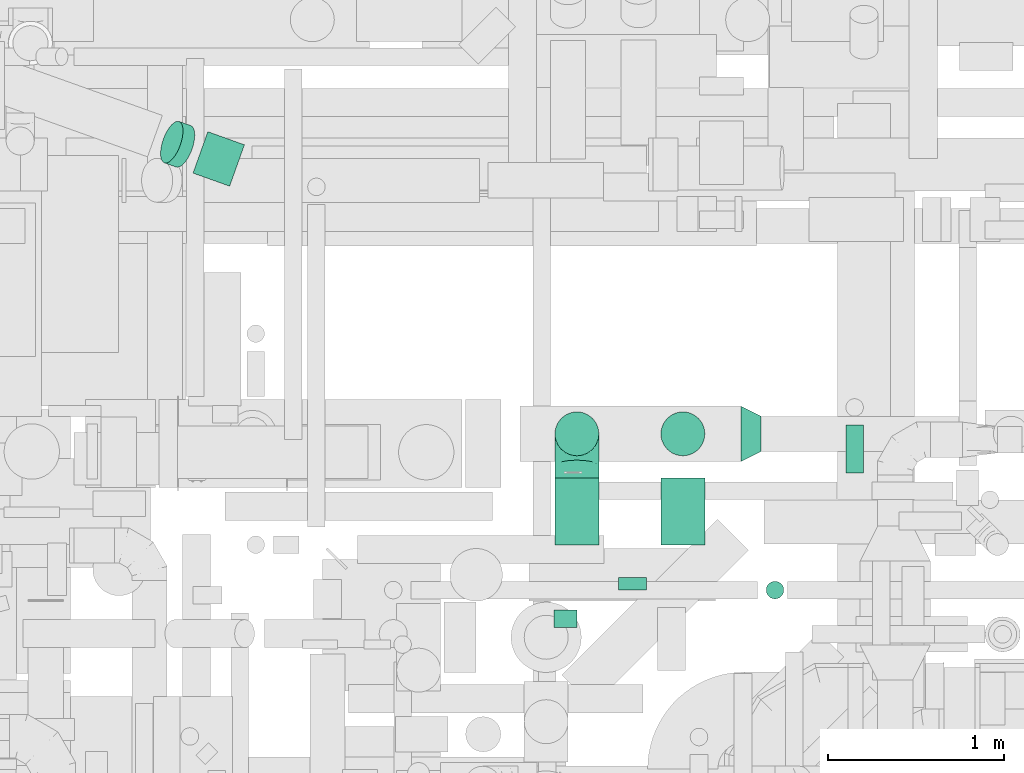
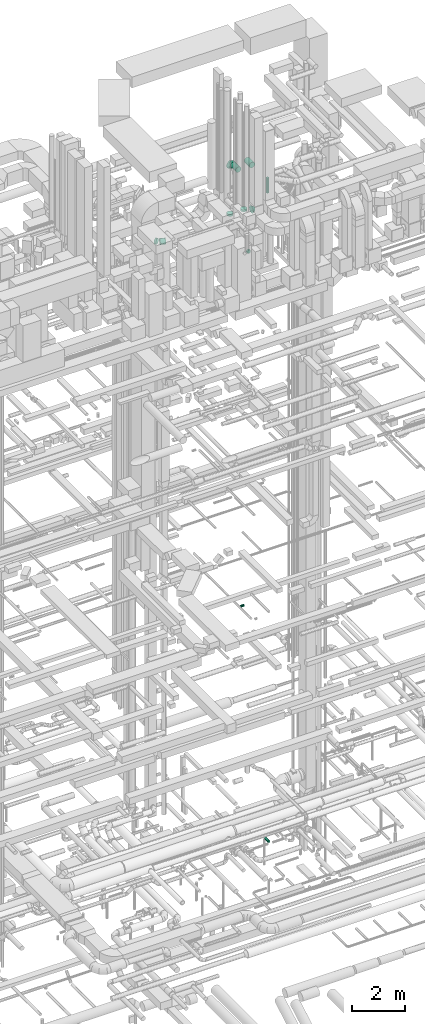
# One storey, part 247 of 337: 8 flow segments, 4 flow fittings.
"""IFC2X3 building model written with IfcOpenShell, lengths in millimetres."""

from ifc_helpers import new_model, entity, si_unit, converted_unit, derived_unit, direction, frame, origin, origin_2d_with_axis, place, context, subcontext, project, spatial, circle, extrude, faceted_brep, source, transform, mapped, material, type_object, type_shapes, element, save


model = new_model("IFC2X3")

# Units and contexts
model_context = context("Model", 3, precision=0.01, world=origin(), true_north=direction((6.12303176911189e-17, 1.0)))
body_context = subcontext(model_context, "Body", "Model", "MODEL_VIEW")
ifc_project = project(units=[si_unit("LENGTHUNIT", "METRE", prefix="MILLI"), si_unit("AREAUNIT", "SQUARE_METRE"), si_unit("VOLUMEUNIT", "CUBIC_METRE"), converted_unit("PLANEANGLEUNIT", "DEGREE", entity("IfcRatioMeasure", 0.0174532925199433), si_unit("PLANEANGLEUNIT", "RADIAN"), dimensions=[0, 0, 0, 0, 0, 0, 0]), si_unit("MASSUNIT", "GRAM", prefix="KILO"), derived_unit("MASSDENSITYUNIT", [(si_unit("MASSUNIT", "GRAM", prefix="KILO"), 1), (si_unit("LENGTHUNIT", "METRE"), -3)]), derived_unit("MOMENTOFINERTIAUNIT", [(si_unit("LENGTHUNIT", "METRE"), 4)]), si_unit("TIMEUNIT", "SECOND"), si_unit("FREQUENCYUNIT", "HERTZ"), si_unit("THERMODYNAMICTEMPERATUREUNIT", "DEGREE_CELSIUS"), derived_unit("THERMALTRANSMITTANCEUNIT", [(si_unit("MASSUNIT", "GRAM", prefix="KILO"), 1), (si_unit("THERMODYNAMICTEMPERATUREUNIT", "KELVIN"), -1), (si_unit("TIMEUNIT", "SECOND"), -3)]), derived_unit("VOLUMETRICFLOWRATEUNIT", [(si_unit("LENGTHUNIT", "METRE"), 3), (si_unit("TIMEUNIT", "SECOND"), -1)]), derived_unit("MASSFLOWRATEUNIT", [(si_unit("MASSUNIT", "GRAM", prefix="KILO"), 1), (si_unit("TIMEUNIT", "SECOND"), -1)]), derived_unit("ROTATIONALFREQUENCYUNIT", [(si_unit("TIMEUNIT", "SECOND"), -1)]), si_unit("ELECTRICCURRENTUNIT", "AMPERE"), si_unit("ELECTRICVOLTAGEUNIT", "VOLT"), si_unit("POWERUNIT", "WATT"), si_unit("FORCEUNIT", "NEWTON", prefix="KILO"), si_unit("ILLUMINANCEUNIT", "LUX"), si_unit("LUMINOUSFLUXUNIT", "LUMEN"), si_unit("LUMINOUSINTENSITYUNIT", "CANDELA"), derived_unit("USERDEFINED", [(si_unit("MASSUNIT", "GRAM", prefix="KILO"), -1), (si_unit("LENGTHUNIT", "METRE"), -2), (si_unit("TIMEUNIT", "SECOND"), 3), (si_unit("LUMINOUSFLUXUNIT", "LUMEN"), 1)]), derived_unit("LINEARVELOCITYUNIT", [(si_unit("LENGTHUNIT", "METRE"), 1), (si_unit("TIMEUNIT", "SECOND"), -1)]), si_unit("PRESSUREUNIT", "PASCAL"), derived_unit("USERDEFINED", [(si_unit("LENGTHUNIT", "METRE"), -2), (si_unit("MASSUNIT", "GRAM", prefix="KILO"), 1), (si_unit("TIMEUNIT", "SECOND"), -2)]), derived_unit("LINEARFORCEUNIT", [(si_unit("MASSUNIT", "GRAM", prefix="KILO"), 1), (si_unit("LENGTHUNIT", "METRE"), 1), (si_unit("TIMEUNIT", "SECOND"), -2), (si_unit("LENGTHUNIT", "METRE"), -1)]), derived_unit("PLANARFORCEUNIT", [(si_unit("MASSUNIT", "GRAM", prefix="KILO"), 1), (si_unit("LENGTHUNIT", "METRE"), 1), (si_unit("TIMEUNIT", "SECOND"), -2), (si_unit("LENGTHUNIT", "METRE"), -2)])], contexts=[model_context])

# Site, building, storey
site_placement = place(None, origin())
site = spatial("IfcSite", under=ifc_project, at=site_placement, CompositionType="ELEMENT")
building_placement = place(site_placement, origin())
building = spatial("IfcBuilding", under=site, at=building_placement, CompositionType="ELEMENT")
storey_placement = place(building_placement, origin())
storey = spatial("IfcBuildingStorey", under=building, at=storey_placement, CompositionType="ELEMENT", Elevation=0.0)

# Flow segments
duct_segment_type = type_object("IfcDuctSegmentType", PredefinedType="NOTDEFINED")
flow_segment_1_placement = place(storey_placement, frame((58022.61, 12771.08, -571.6)))
element("IfcFlowSegment", 1, at=flow_segment_1_placement, inside=storey, type_object=duct_segment_type, context=body_context, shape_type="SweptSolid", body=[
    extrude(circle(Radius=50.0, at=origin_2d_with_axis()), frame((51.6, 0.0, 51.6), z_axis=(0.0, 1.0, 0.0), x_axis=(1.0, 0.0, 0.0)), (0.0, 0.0, 1.0), 272.933650000004),
])
flow_segment_2_placement = place(storey_placement, frame((56365.61, 11891.09, 11398.4)))
element("IfcFlowSegment", 2, at=flow_segment_2_placement, inside=storey, type_object=duct_segment_type, context=body_context, shape_type="SweptSolid", body=[
    extrude(circle(Radius=50.0, at=origin_2d_with_axis()), frame((0.0, 51.6, 51.6), z_axis=(1.0, 0.0, 0.0), x_axis=(0.0, -1.0, 0.0)), (0.0, 0.0, 1.0), 129.999999999996),
])
flow_segment_3_placement = place(storey_placement, frame((54310.89, 14400.57, 27248.4)))
element("IfcFlowSegment", 3, at=flow_segment_3_placement, inside=storey, type_object=duct_segment_type, context=body_context, shape_type="SweptSolid", body=[
    extrude(circle(Radius=125.0, at=origin_2d_with_axis()), frame((251.86, 119.31, 126.6), z_axis=(-0.941697054037876, 0.336461971723976, 0.0), x_axis=(0.336461971723976, 0.941697054037876, 0.0)), (0.0, 0.0, 1.0), 221.096156269276),
])
flow_segment_4_placement = place(storey_placement, frame((54126.49, 14508.78, 27280.87)))
element("IfcFlowSegment", 4, at=flow_segment_4_placement, inside=storey, type_object=duct_segment_type, context=body_context, shape_type="SweptSolid", body=[
    extrude(circle(Radius=125.0, at=origin_2d_with_axis()), frame((65.21, 143.67, 147.49), z_axis=(0.860171315661205, -0.307333378231114, -0.407003074114584), x_axis=(0.336461971723953, 0.941697054037884, 0.0)), (0.0, 0.0, 1.0), 77.9192988655578),
])
flow_segment_5_placement = place(storey_placement, frame((56728.62, 12106.18, 27468.4)))
element("IfcFlowSegment", 5, at=flow_segment_5_placement, inside=storey, type_object=duct_segment_type, context=body_context, shape_type="SweptSolid", body=[
    extrude(circle(Radius=80.0, at=origin_2d_with_axis()), frame((81.6, 0.0, 81.6), z_axis=(0.0, 1.0, 0.0), x_axis=(-1.0, 0.0, 0.0)), (0.0, 0.0, 1.0), 70.0000000000296),
])
flow_segment_6_placement = place(storey_placement, frame((56368.56, 12362.32, 31173.4)))
element("IfcFlowSegment", 6, at=flow_segment_6_placement, inside=storey, type_object=duct_segment_type, context=body_context, shape_type="SweptSolid", body=[
    extrude(circle(Radius=125.0, at=origin_2d_with_axis()), frame((126.6, 0.0, 126.6), z_axis=(0.0, 1.0, 0.0), x_axis=(1.0, 0.0, 0.0)), (0.0, 0.0, 1.0), 381.693644852555),
])
flow_segment_7_placement = place(storey_placement, frame((56971.06, 12362.32, 31173.4)))
element("IfcFlowSegment", 7, at=flow_segment_7_placement, inside=storey, type_object=duct_segment_type, context=body_context, shape_type="SweptSolid", body=[
    extrude(circle(Radius=125.0, at=origin_2d_with_axis()), frame((126.6, 0.0, 126.6), z_axis=(0.0, 1.0, 0.0), x_axis=(-1.0, 0.0, 0.0)), (0.0, 0.0, 1.0), 381.693644852546),
])
flow_segment_8_placement = place(storey_placement, frame((57569.9, 12054.04, 30000.0)))
element("IfcFlowSegment", 8, at=flow_segment_8_placement, inside=storey, type_object=duct_segment_type, context=body_context, shape_type="SweptSolid", body=[
    extrude(circle(Radius=50.0, at=origin_2d_with_axis()), frame((51.6, 51.6, 0.0), z_axis=(0.0, 0.0, 1.0), x_axis=(0.0, -1.0, 0.0)), (0.0, 0.0, 1.0), 699.999999999993),
])

# Flow fittings
ifc_material = material()
duct_fitting_type_1 = type_object("IfcDuctFittingType", PredefinedType="NOTDEFINED", material=ifc_material)
shared_shape_1 = source(origin(), body_context, "Body", "Brep", [
    faceted_brep([(-250.0, 0.0, -125.0), (-250.0, -32.35, -120.74), (-250.0, -62.5, -108.25), (-250.0, -88.39, -88.39), (-250.0, -108.25, -62.5), (-250.0, -120.74, -32.35), (-250.0, -125.0, 0.0), (-250.0, -120.74, 32.35), (-250.0, -108.25, 62.5), (-250.0, -88.39, 88.39), (-250.0, -62.5, 108.25), (-250.0, -32.35, 120.74), (-250.0, 0.0, 125.0), (-250.0, 32.35, 120.74), (-250.0, 62.5, 108.25), (-250.0, 88.39, 88.39), (-250.0, 108.25, 62.5), (-250.0, 120.74, 32.35), (-250.0, 125.0, 0.0), (-250.0, 120.74, -32.35), (-250.0, 108.25, -62.5), (-250.0, 88.39, -88.39), (-250.0, 62.5, -108.25), (-250.0, 32.35, -120.74), (-191.68, 32.35, 120.74), (-199.76, 62.5, 108.25), (-183.01, 0.0, 125.0), (-206.7, 88.39, 88.39), (-215.37, 120.74, 32.35), (-216.51, 125.0, 0.0), (-212.02, 108.25, 62.5), (-212.02, 108.25, -62.5), (-206.7, 88.39, -88.39), (-215.37, 120.74, -32.35), (-191.68, 32.35, -120.74), (-183.01, 0.0, -125.0), (-199.76, 62.5, -108.25), (-174.34, -32.35, -120.74), (-166.27, -62.5, -108.25), (-159.33, -88.39, -88.39), (-154.01, -108.25, -62.5), (-150.66, -120.74, -32.35), (-149.52, -125.0, 0.0), (-150.66, -120.74, 32.35), (-154.01, -108.25, 62.5), (-159.33, -88.39, 88.39), (-166.27, -62.5, 108.25), (-174.34, -32.35, 120.74), (-90.67, 90.67, 120.74), (-112.74, 112.74, 108.25), (-66.99, 66.99, 125.0), (-131.69, 131.69, 88.39), (-146.23, 146.23, 62.5), (-155.38, 155.38, 32.35), (-158.49, 158.49, 0.0), (-155.38, 155.38, -32.35), (-146.23, 146.23, -62.5), (-131.69, 131.69, -88.39), (-90.67, 90.67, -120.74), (-66.99, 66.99, -125.0), (-112.74, 112.74, -108.25), (-43.3, 43.3, -120.74), (-21.23, 21.23, -108.25), (-2.28, 2.28, -88.39), (12.26, -12.26, -62.5), (21.4, -21.4, -32.35), (24.52, -24.52, 0.0), (21.4, -21.4, 32.35), (12.26, -12.26, 62.5), (-2.28, 2.28, 88.39), (-21.23, 21.23, 108.25), (-43.3, 43.3, 120.74), (-32.35, 191.68, 120.74), (-62.5, 199.76, 108.25), (0.0, 183.01, 125.0), (-88.39, 206.7, 88.39), (-108.25, 212.02, 62.5), (-120.74, 215.37, 32.35), (-125.0, 216.51, 0.0), (-120.74, 215.37, -32.35), (-108.25, 212.02, -62.5), (-88.39, 206.7, -88.39), (-32.35, 191.68, -120.74), (0.0, 183.01, -125.0), (-62.5, 199.76, -108.25), (32.35, 174.34, -120.74), (62.5, 166.27, -108.25), (88.39, 159.33, -88.39), (108.25, 154.01, -62.5), (120.74, 150.66, -32.35), (125.0, 149.52, 0.0), (120.74, 150.66, 32.35), (108.25, 154.01, 62.5), (88.39, 159.33, 88.39), (62.5, 166.27, 108.25), (32.35, 174.34, 120.74), (-32.35, 250.0, -120.74), (-62.5, 250.0, -108.25), (-88.39, 250.0, -88.39), (-108.25, 250.0, -62.5), (-120.74, 250.0, -32.35), (-125.0, 250.0, 0.0), (-120.74, 250.0, 32.35), (-108.25, 250.0, 62.5), (-88.39, 250.0, 88.39), (-62.5, 250.0, 108.25), (-32.35, 250.0, 120.74), (0.0, 250.0, 125.0), (32.35, 250.0, 120.74), (62.5, 250.0, 108.25), (88.39, 250.0, 88.39), (108.25, 250.0, 62.5), (120.74, 250.0, 32.35), (125.0, 250.0, 0.0), (120.74, 250.0, -32.35), (108.25, 250.0, -62.5), (88.39, 250.0, -88.39), (62.5, 250.0, -108.25), (32.35, 250.0, -120.74), (0.0, 250.0, -125.0)], [[[0, 1, 2, 3, 4, 5, 6, 7, 8, 9, 10, 11, 12, 13, 14, 15, 16, 17, 18, 19, 20, 21, 22, 23]], [[24, 25, 14, 13]], [[26, 24, 13, 12]], [[14, 25, 27, 15]], [[28, 29, 18, 17]], [[30, 28, 17, 16]], [[15, 27, 30, 16]], [[20, 31, 32, 21]], [[33, 31, 20, 19]], [[18, 29, 33, 19]], [[34, 35, 0, 23]], [[36, 34, 23, 22]], [[21, 32, 36, 22]], [[1, 0, 35, 37]], [[2, 1, 37, 38]], [[38, 39, 3, 2]], [[5, 4, 40, 41]], [[6, 5, 41, 42]], [[39, 40, 4, 3]], [[6, 42, 43, 7]], [[7, 43, 44, 8]], [[8, 44, 45, 9]], [[9, 45, 46, 10]], [[10, 46, 47, 11]], [[26, 12, 11, 47]], [[48, 49, 25, 24]], [[50, 48, 24, 26]], [[27, 25, 49, 51]], [[52, 53, 28, 30]], [[51, 52, 30, 27]], [[29, 28, 53, 54]], [[55, 56, 31, 33]], [[54, 55, 33, 29]], [[32, 31, 56, 57]], [[58, 59, 35, 34]], [[60, 58, 34, 36]], [[57, 60, 36, 32]], [[37, 35, 59, 61]], [[38, 37, 61, 62]], [[39, 38, 62, 63]], [[41, 40, 64, 65]], [[42, 41, 65, 66]], [[63, 64, 40, 39]], [[43, 42, 66, 67]], [[44, 43, 67, 68]], [[68, 69, 45, 44]], [[46, 45, 69, 70]], [[47, 46, 70, 71]], [[26, 47, 71, 50]], [[72, 73, 49, 48]], [[74, 72, 48, 50]], [[51, 49, 73, 75]], [[76, 77, 53, 52]], [[75, 76, 52, 51]], [[54, 53, 77, 78]], [[79, 80, 56, 55]], [[78, 79, 55, 54]], [[57, 56, 80, 81]], [[82, 83, 59, 58]], [[84, 82, 58, 60]], [[81, 84, 60, 57]], [[61, 59, 83, 85]], [[62, 61, 85, 86]], [[63, 62, 86, 87]], [[65, 64, 88, 89]], [[66, 65, 89, 90]], [[87, 88, 64, 63]], [[67, 66, 90, 91]], [[68, 67, 91, 92]], [[92, 93, 69, 68]], [[70, 69, 93, 94]], [[71, 70, 94, 95]], [[50, 71, 95, 74]], [[96, 97, 98, 99, 100, 101, 102, 103, 104, 105, 106, 107, 108, 109, 110, 111, 112, 113, 114, 115, 116, 117, 118, 119]], [[72, 74, 107, 106]], [[73, 72, 106, 105]], [[75, 73, 105, 104]], [[77, 76, 103, 102]], [[78, 77, 102, 101]], [[75, 104, 103, 76]], [[78, 101, 100, 79]], [[79, 100, 99, 80]], [[80, 99, 98, 81]], [[84, 97, 96, 82]], [[82, 96, 119, 83]], [[84, 81, 98, 97]], [[83, 119, 118, 85]], [[85, 118, 117, 86]], [[116, 87, 86, 117]], [[88, 115, 114, 89]], [[89, 114, 113, 90]], [[115, 88, 87, 116]], [[91, 90, 113, 112]], [[92, 91, 112, 111]], [[111, 110, 93, 92]], [[95, 94, 109, 108]], [[74, 95, 108, 107]], [[110, 109, 94, 93]]]),
])
type_shapes(duct_fitting_type_1, [shared_shape_1])
flow_fitting_1_placement = place(storey_placement, frame((56495.15, 12994.01, 31300.0), z_axis=(1.0, 0.0, 0.0), x_axis=(0.0, 0.0, 1.0)))
element("IfcFlowFitting", 9, at=flow_fitting_1_placement, inside=storey, type_object=duct_fitting_type_1, material=ifc_material, context=body_context, shape_type="MappedRepresentation", body=[
    mapped(shared_shape_1, transform((0.0, 0.0, 0.0), scale=1.0)),
])
duct_fitting_type_2 = type_object("IfcDuctFittingType", PredefinedType="NOTDEFINED", material=ifc_material)
shared_shape_2 = source(origin(), body_context, "Body", "Brep", [
    faceted_brep([(20.0, 32.35, -120.74), (20.0, 62.5, -108.25), (20.0, 88.39, -88.39), (20.0, 108.25, -62.5), (20.0, 120.74, -32.35), (20.0, 125.0, 0.0), (20.0, 120.74, 32.35), (20.0, 108.25, 62.5), (20.0, 88.39, 88.39), (20.0, 62.5, 108.25), (20.0, 32.35, 120.74), (20.0, 0.0, 125.0), (20.0, -32.35, 120.74), (20.0, -62.5, 108.25), (20.0, -88.39, 88.39), (20.0, -108.25, 62.5), (20.0, -120.74, 32.35), (20.0, -125.0, 0.0), (20.0, -120.74, -32.35), (20.0, -108.25, -62.5), (20.0, -88.39, -88.39), (20.0, -62.5, -108.25), (20.0, -32.35, -120.74), (20.0, 0.0, -125.0), (0.0, 0.0, 125.0), (0.0, 32.35, 120.74), (-67.78, 32.35, 120.74), (-67.78, 0.0, 125.0), (0.0, 62.5, 108.25), (-67.78, 62.5, 108.25), (0.0, 88.39, 88.39), (-67.78, 88.39, 88.39), (0.0, 108.25, 62.5), (0.0, 120.74, 32.35), (-67.78, 120.74, 32.35), (-67.78, 108.25, 62.5), (0.0, 125.0, 0.0), (-67.78, 125.0, 0.0), (0.0, 120.74, -32.35), (-67.78, 120.74, -32.35), (0.0, 108.25, -62.5), (-67.78, 108.25, -62.5), (0.0, 88.39, -88.39), (-67.78, 88.39, -88.39), (0.0, 62.5, -108.25), (0.0, 32.35, -120.74), (-67.78, 32.35, -120.74), (-67.78, 62.5, -108.25), (0.0, 0.0, -125.0), (-67.78, 0.0, -125.0), (0.0, -32.35, -120.74), (-67.78, -32.35, -120.74), (0.0, -62.5, -108.25), (-67.78, -62.5, -108.25), (0.0, -88.39, -88.39), (-67.78, -88.39, -88.39), (0.0, -108.25, -62.5), (0.0, -120.74, -32.35), (-67.78, -120.74, -32.35), (-67.78, -108.25, -62.5), (0.0, -125.0, 0.0), (-67.78, -125.0, 0.0), (0.0, -120.74, 32.35), (-67.78, -120.74, 32.35), (0.0, -108.25, 62.5), (-67.78, -108.25, 62.5), (0.0, -88.39, 88.39), (-67.78, -88.39, 88.39), (0.0, -62.5, 108.25), (0.0, -32.35, 120.74), (-67.78, -32.35, 120.74), (-67.78, -62.5, 108.25)], [[[0, 1, 2, 3, 4, 5, 6, 7, 8, 9, 10, 11, 12, 13, 14, 15, 16, 17, 18, 19, 20, 21, 22, 23]], [[24, 11, 10, 25, 26, 27]], [[25, 10, 9, 28, 29, 26]], [[28, 9, 8, 30, 31, 29]], [[32, 7, 6, 33, 34, 35]], [[33, 6, 5, 36, 37, 34]], [[30, 8, 7, 32, 35, 31]], [[36, 5, 4, 38, 39, 37]], [[38, 4, 3, 40, 41, 39]], [[40, 3, 2, 42, 43, 41]], [[44, 1, 0, 45, 46, 47]], [[45, 0, 23, 48, 49, 46]], [[42, 2, 1, 44, 47, 43]], [[48, 23, 22, 50, 51, 49]], [[50, 22, 21, 52, 53, 51]], [[52, 21, 20, 54, 55, 53]], [[56, 19, 18, 57, 58, 59]], [[57, 18, 17, 60, 61, 58]], [[54, 20, 19, 56, 59, 55]], [[60, 17, 16, 62, 63, 61]], [[62, 16, 15, 64, 65, 63]], [[64, 15, 14, 66, 67, 65]], [[68, 13, 12, 69, 70, 71]], [[69, 12, 11, 24, 27, 70]], [[66, 14, 13, 68, 71, 67]], [[49, 51, 53, 55, 59, 58, 61, 63, 65, 67, 71, 70, 27, 26, 29, 31, 35, 34, 37, 39, 41, 43, 47, 46]]]),
])
type_shapes(duct_fitting_type_2, [shared_shape_2])
for number, where, z_axis, x_axis in (
    (10, (57097.66, 12994.01, 28907.5), (1.0, 0.0, 0.0), (0.0, 0.0, 1.0)),
    (11, (56495.15, 12994.01, 28907.5), (1.0, 0.0, 0.0), (0.0, 0.0, 1.0)),
):
    element("IfcFlowFitting", number, at=place(storey_placement, frame(where, z_axis=z_axis, x_axis=x_axis)), inside=storey, type_object=duct_fitting_type_2, material=ifc_material, context=body_context, shape_type="MappedRepresentation", body=[
        mapped(shared_shape_2, transform((0.0, 0.0, 0.0), scale=1.0)),
    ])
duct_fitting_type_3 = type_object("IfcDuctFittingType", PredefinedType="NOTDEFINED", material=ifc_material)
shared_shape_3 = source(origin(), body_context, "Body", "Brep", [
    faceted_brep([(115.0, 80.9, -58.78), (115.0, 95.11, -30.9), (115.0, 100.0, 0.0), (115.0, 95.11, 30.9), (115.0, 80.9, 58.78), (115.0, 58.78, 80.9), (115.0, 30.9, 95.11), (115.0, 0.0, 100.0), (115.0, -30.9, 95.11), (115.0, -58.78, 80.9), (115.0, -80.9, 58.78), (115.0, -95.11, 30.9), (115.0, -100.0, 0.0), (115.0, -95.11, -30.9), (115.0, -80.9, -58.78), (115.0, -58.78, -80.9), (115.0, -30.9, -95.11), (115.0, 0.0, -100.0), (115.0, 30.9, -95.11), (115.0, 58.78, -80.9), (0.0, -40.76, -152.13), (0.0, -78.75, -136.4), (0.0, -111.37, -111.37), (0.0, -136.4, -78.75), (0.0, -152.13, -40.76), (0.0, -157.5, 0.0), (0.0, -152.13, 40.76), (0.0, -136.4, 78.75), (0.0, -111.37, 111.37), (0.0, -78.75, 136.4), (0.0, -40.76, 152.13), (0.0, 0.0, 157.5), (0.0, 40.76, 152.13), (0.0, 78.75, 136.4), (0.0, 111.37, 111.37), (0.0, 136.4, 78.75), (0.0, 152.13, 40.76), (0.0, 157.5, 0.0), (0.0, 152.13, -40.76), (0.0, 136.4, -78.75), (0.0, 111.37, -111.37), (0.0, 78.75, -136.4), (0.0, 40.76, -152.13), (0.0, 0.0, -157.5)], [[[0, 1, 2, 3, 4, 5, 6, 7, 8, 9, 10, 11, 12, 13, 14, 15, 16, 17, 18, 19]], [[20, 21, 22, 23, 24, 25, 26, 27, 28, 29, 30, 31, 32, 33, 34, 35, 36, 37, 38, 39, 40, 41, 42, 43]], [[6, 5, 33]], [[7, 6, 32]], [[7, 32, 31]], [[32, 6, 33]], [[5, 34, 33]], [[35, 4, 3]], [[36, 3, 2]], [[35, 34, 4]], [[37, 36, 2]], [[35, 3, 36]], [[4, 34, 5]], [[11, 10, 27]], [[12, 11, 26]], [[12, 26, 25]], [[26, 11, 27]], [[10, 28, 27]], [[29, 9, 8]], [[30, 8, 7]], [[29, 28, 9]], [[31, 30, 7]], [[29, 8, 30]], [[9, 28, 10]], [[16, 15, 21]], [[17, 16, 20]], [[17, 20, 43]], [[20, 16, 21]], [[15, 22, 21]], [[23, 14, 13]], [[24, 13, 12]], [[23, 22, 14]], [[25, 24, 12]], [[23, 13, 24]], [[14, 22, 15]], [[1, 0, 39]], [[2, 1, 38]], [[2, 38, 37]], [[38, 1, 39]], [[0, 40, 39]], [[41, 19, 18]], [[42, 18, 17]], [[41, 40, 19]], [[43, 42, 17]], [[41, 18, 42]], [[19, 40, 0]]]),
])
type_shapes(duct_fitting_type_3, [shared_shape_3])
flow_fitting_2_placement = place(storey_placement, frame((57427.66, 12994.01, 28750.0)))
element("IfcFlowFitting", 12, at=flow_fitting_2_placement, inside=storey, type_object=duct_fitting_type_3, material=ifc_material, context=body_context, shape_type="MappedRepresentation", body=[
    mapped(shared_shape_3, transform((0.0, 0.0, 0.0), scale=1.0)),
])

save(model, "model.ifc")
